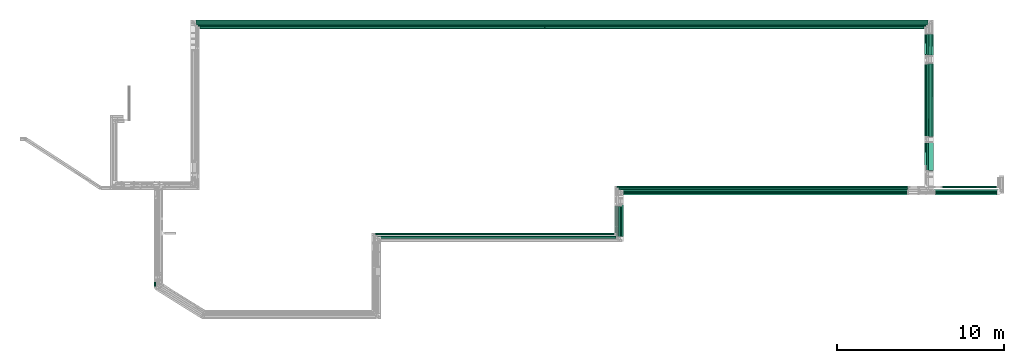
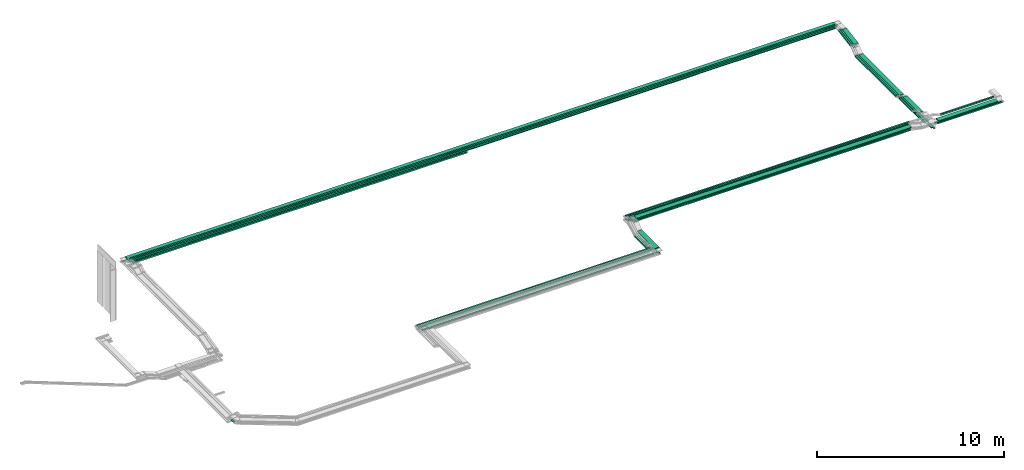
# One storey, part 2 of 14: 42 flow segments.
"""IFC2X3 building model written with IfcOpenShell, lengths in millimetres."""

from ifc_helpers import new_model, entity, si_unit, converted_unit, derived_unit, direction, frame, frame_2d, origin, origin_2d_with_axis, place, context, subcontext, project, spatial, rectangle, extrude, type_object, element, save


model = new_model("IFC2X3")

# Units and contexts
model_context = context("Model", 3, precision=0.01, world=origin(), true_north=direction((6.12303176911189e-17, 1.0)))
body_context = subcontext(model_context, "Body", "Model", "MODEL_VIEW")
ifc_project = project(units=[si_unit("LENGTHUNIT", "METRE", prefix="MILLI"), si_unit("AREAUNIT", "SQUARE_METRE"), si_unit("VOLUMEUNIT", "CUBIC_METRE"), converted_unit("PLANEANGLEUNIT", "DEGREE", entity("IfcRatioMeasure", 0.0174532925199433), si_unit("PLANEANGLEUNIT", "RADIAN"), dimensions=[0, 0, 0, 0, 0, 0, 0]), si_unit("MASSUNIT", "GRAM", prefix="KILO"), derived_unit("MASSDENSITYUNIT", [(si_unit("MASSUNIT", "GRAM", prefix="KILO"), 1), (si_unit("LENGTHUNIT", "METRE"), -3)]), derived_unit("MOMENTOFINERTIAUNIT", [(si_unit("LENGTHUNIT", "METRE"), 4)]), si_unit("TIMEUNIT", "SECOND"), si_unit("FREQUENCYUNIT", "HERTZ"), si_unit("THERMODYNAMICTEMPERATUREUNIT", "DEGREE_CELSIUS"), derived_unit("THERMALTRANSMITTANCEUNIT", [(si_unit("MASSUNIT", "GRAM", prefix="KILO"), 1), (si_unit("THERMODYNAMICTEMPERATUREUNIT", "KELVIN"), -1), (si_unit("TIMEUNIT", "SECOND"), -3)]), derived_unit("VOLUMETRICFLOWRATEUNIT", [(si_unit("LENGTHUNIT", "METRE"), 3), (si_unit("TIMEUNIT", "SECOND"), -1)]), derived_unit("MASSFLOWRATEUNIT", [(si_unit("MASSUNIT", "GRAM", prefix="KILO"), 1), (si_unit("TIMEUNIT", "SECOND"), -1)]), derived_unit("ROTATIONALFREQUENCYUNIT", [(si_unit("TIMEUNIT", "SECOND"), -1)]), si_unit("ELECTRICCURRENTUNIT", "AMPERE"), si_unit("ELECTRICVOLTAGEUNIT", "VOLT"), si_unit("POWERUNIT", "WATT"), si_unit("FORCEUNIT", "NEWTON", prefix="KILO"), si_unit("ILLUMINANCEUNIT", "LUX"), si_unit("LUMINOUSFLUXUNIT", "LUMEN"), si_unit("LUMINOUSINTENSITYUNIT", "CANDELA"), derived_unit("USERDEFINED", [(si_unit("MASSUNIT", "GRAM", prefix="KILO"), -1), (si_unit("LENGTHUNIT", "METRE"), -2), (si_unit("TIMEUNIT", "SECOND"), 3), (si_unit("LUMINOUSFLUXUNIT", "LUMEN"), 1)]), derived_unit("LINEARVELOCITYUNIT", [(si_unit("LENGTHUNIT", "METRE"), 1), (si_unit("TIMEUNIT", "SECOND"), -1)]), si_unit("PRESSUREUNIT", "PASCAL"), derived_unit("USERDEFINED", [(si_unit("LENGTHUNIT", "METRE"), -2), (si_unit("MASSUNIT", "GRAM", prefix="KILO"), 1), (si_unit("TIMEUNIT", "SECOND"), -2)]), derived_unit("LINEARFORCEUNIT", [(si_unit("MASSUNIT", "GRAM", prefix="KILO"), 1), (si_unit("LENGTHUNIT", "METRE"), 1), (si_unit("TIMEUNIT", "SECOND"), -2), (si_unit("LENGTHUNIT", "METRE"), -1)]), derived_unit("PLANARFORCEUNIT", [(si_unit("MASSUNIT", "GRAM", prefix="KILO"), 1), (si_unit("LENGTHUNIT", "METRE"), 1), (si_unit("TIMEUNIT", "SECOND"), -2), (si_unit("LENGTHUNIT", "METRE"), -2)])], contexts=[model_context])

# Site, building, storey
site_placement = place(None, origin())
site = spatial("IfcSite", under=ifc_project, at=site_placement, CompositionType="ELEMENT")
building_placement = place(site_placement, origin())
building = spatial("IfcBuilding", under=site, at=building_placement, CompositionType="ELEMENT")
storey_placement = place(building_placement, frame((0.0, 0.0, 19800.0)))
storey = spatial("IfcBuildingStorey", under=building, at=storey_placement, CompositionType="ELEMENT", Elevation=19800.0)

# Flow segments
cable_carrier_segment_type = type_object("IfcCableCarrierSegmentType", PredefinedType="CABLETRAYSEGMENT")
flow_segment_1_placement = place(storey_placement, frame((20510.22, 19700.0, 3300.0)))
element("IfcFlowSegment", 1, at=flow_segment_1_placement, inside=storey, type_object=cable_carrier_segment_type, context=body_context, shape_type="SweptSolid", body=[
    extrude(rectangle(XDim=43861.6970823392, YDim=300.000000000001, at=origin_2d_with_axis()), frame((21930.85, 150.0, 0.0), z_axis=(3.27264479763197e-08, 0.0, 1.0), x_axis=(-1.0, 0.0, 3.27264479763197e-08)), (0.0, 0.0, 1.0), 49.9999999999973),
])
flow_segment_2_placement = place(storey_placement, frame((20615.22, 19595.0, 3300.0)))
element("IfcFlowSegment", 2, at=flow_segment_2_placement, inside=storey, type_object=cable_carrier_segment_type, context=body_context, shape_type="SweptSolid", body=[
    extrude(rectangle(XDim=43650.3107133575, YDim=100.000000000003, at=origin_2d_with_axis()), frame((21825.16, 50.0, 0.0), z_axis=(0.0, 0.0, 1.0), x_axis=(-1.0, 0.0, 0.0)), (0.0, 0.0, 1.0), 100.000000000003),
])
flow_segment_3_placement = place(storey_placement, frame((20720.22, 19490.0, 3300.0)))
element("IfcFlowSegment", 3, at=flow_segment_3_placement, inside=storey, type_object=cable_carrier_segment_type, context=body_context, shape_type="SweptSolid", body=[
    extrude(rectangle(XDim=43439.8425431613, YDim=100.000000000001, at=origin_2d_with_axis()), frame((21719.92, 50.0, 0.0), z_axis=(0.0, 0.0, 1.0), x_axis=(-1.0, 0.0, 0.0)), (0.0, 0.0, 1.0), 100.000000000003),
])
flow_segment_4_placement = place(storey_placement, frame((64593.04, 9615.0, 2550.0)))
element("IfcFlowSegment", 4, at=flow_segment_4_placement, inside=storey, type_object=cable_carrier_segment_type, context=body_context, shape_type="SweptSolid", body=[
    extrude(rectangle(XDim=7760.0992906484, YDim=99.9999999999946, at=origin_2d_with_axis()), frame((50.0, 3880.05, 0.0), z_axis=(0.0, 0.0, 1.0), x_axis=(0.0, -1.0, 0.0)), (0.0, 0.0, 1.0), 49.9999999999973),
])
flow_segment_5_placement = place(storey_placement, frame((64490.53, 9720.0, 2550.0)))
element("IfcFlowSegment", 5, at=flow_segment_5_placement, inside=storey, type_object=cable_carrier_segment_type, context=body_context, shape_type="SweptSolid", body=[
    extrude(rectangle(XDim=7655.09929065903, YDim=99.9999999999946, at=origin_2d_with_axis()), frame((50.0, 3827.55, 0.0), z_axis=(0.0, 0.0, 1.0), x_axis=(0.0, -1.0, 0.0)), (0.0, 0.0, 1.0), 49.9999999999973),
])
flow_segment_6_placement = place(storey_placement, frame((64388.57, 10290.0, 2550.0)))
element("IfcFlowSegment", 6, at=flow_segment_6_placement, inside=storey, type_object=cable_carrier_segment_type, context=body_context, shape_type="SweptSolid", body=[
    extrude(rectangle(XDim=7085.0992906527, YDim=99.9999999999946, at=origin_2d_with_axis()), frame((50.0, 3542.55, 0.0), z_axis=(0.0, 0.0, 1.0), x_axis=(0.0, -1.0, 0.0)), (0.0, 0.0, 1.0), 49.9999999999973),
])
flow_segment_7_placement = place(storey_placement, frame((20720.22, 19490.0, 3100.0)))
element("IfcFlowSegment", 7, at=flow_segment_7_placement, inside=storey, type_object=cable_carrier_segment_type, context=body_context, shape_type="SweptSolid", body=[
    extrude(rectangle(XDim=20698.7834674717, YDim=100.000000000001, at=origin_2d_with_axis()), frame((10349.39, 50.0, 0.0), z_axis=(0.0, 0.0, 1.0), x_axis=(-1.0, 0.0, 0.0)), (0.0, 0.0, 1.0), 100.000000000003),
])
flow_segment_8_placement = place(storey_placement, frame((20310.22, 19900.0, 3100.0)))
element("IfcFlowSegment", 8, at=flow_segment_8_placement, inside=storey, type_object=cable_carrier_segment_type, context=body_context, shape_type="SweptSolid", body=[
    extrude(rectangle(XDim=44262.8208978618, YDim=100.000000000003, at=origin_2d_with_axis()), frame((22131.41, 50.0, 0.0), z_axis=(0.0, 0.0, 1.0), x_axis=(-1.0, 0.0, 0.0)), (0.0, 0.0, 1.0), 49.9999999999973),
])
flow_segment_9_placement = place(storey_placement, frame((20415.22, 19795.0, 3100.0)))
element("IfcFlowSegment", 9, at=flow_segment_9_placement, inside=storey, type_object=cable_carrier_segment_type, context=body_context, shape_type="SweptSolid", body=[
    extrude(rectangle(XDim=44055.3107133575, YDim=100.000000000003, at=origin_2d_with_axis()), frame((22027.66, 50.0, 0.0), z_axis=(0.0, 0.0, 1.0), x_axis=(-1.0, 0.0, 0.0)), (0.0, 0.0, 1.0), 49.9999999999973),
])
flow_segment_10_placement = place(storey_placement, frame((20520.22, 19690.0, 3100.0)))
element("IfcFlowSegment", 10, at=flow_segment_10_placement, inside=storey, type_object=cable_carrier_segment_type, context=body_context, shape_type="SweptSolid", body=[
    extrude(rectangle(XDim=43848.3558915892, YDim=100.000000000003, at=origin_2d_with_axis()), frame((21924.18, 50.0, 0.0), z_axis=(0.0, 0.0, 1.0), x_axis=(-1.0, 0.0, 0.0)), (0.0, 0.0, 1.0), 49.9999999999973),
])
flow_segment_11_placement = place(storey_placement, frame((46136.39, 9515.0, 3175.0)))
element("IfcFlowSegment", 11, at=flow_segment_11_placement, inside=storey, type_object=cable_carrier_segment_type, context=body_context, shape_type="SweptSolid", body=[
    extrude(rectangle(XDim=17012.5626625772, YDim=300.000000000001, at=origin_2d_with_axis()), frame((8506.28, 150.0, 0.0), z_axis=(0.0, 6.09869900927148e-08, 1.0), x_axis=(-1.0, 0.0, 0.0)), (0.0, 0.0, 1.0), 50.0000000000017),
])
flow_segment_12_placement = place(storey_placement, frame((45715.12, 9945.0, 3175.0)))
element("IfcFlowSegment", 12, at=flow_segment_12_placement, inside=storey, type_object=cable_carrier_segment_type, context=body_context, shape_type="SweptSolid", body=[
    extrude(rectangle(XDim=17558.63871242, YDim=99.9999999999989, at=origin_2d_with_axis()), frame((8779.32, 50.0, 0.0), z_axis=(0.0, 0.0, 1.0), x_axis=(-1.0, 0.0, 0.0)), (0.0, 0.0, 1.0), 100.000000000003),
])
flow_segment_13_placement = place(storey_placement, frame((31167.89, 7125.0, 2800.0)))
element("IfcFlowSegment", 13, at=flow_segment_13_placement, inside=storey, type_object=cable_carrier_segment_type, context=body_context, shape_type="SweptSolid", body=[
    extrude(rectangle(XDim=14407.2299237504, YDim=100.000000000001, at=origin_2d_with_axis()), frame((7203.61, 50.0, 0.0), z_axis=(0.0, 0.0, 1.0), x_axis=(-1.0, 0.0, 0.0)), (0.0, 0.0, 1.0), 100.000000000003),
])
flow_segment_14_placement = place(storey_placement, frame((31369.29, 6927.78, 2600.0)))
element("IfcFlowSegment", 14, at=flow_segment_14_placement, inside=storey, type_object=cable_carrier_segment_type, context=body_context, shape_type="SweptSolid", body=[
    extrude(rectangle(XDim=14320.0, YDim=99.9999999999989, at=origin_2d_with_axis()), frame((7160.0, 50.0, 0.0), z_axis=(0.0, 0.0, 1.0), x_axis=(-1.0, 0.0, 0.0)), (0.0, 0.0, 1.0), 49.9999999999973),
])
flow_segment_15_placement = place(storey_placement, frame((31245.11, 7125.0, 2600.0)))
element("IfcFlowSegment", 15, at=flow_segment_15_placement, inside=storey, type_object=cable_carrier_segment_type, context=body_context, shape_type="SweptSolid", body=[
    extrude(rectangle(XDim=14330.0132597468, YDim=99.9999999999989, at=origin_2d_with_axis()), frame((7165.01, 50.0, 0.0), z_axis=(0.0, 0.0, 1.0), x_axis=(-1.0, 0.0, 0.0)), (0.0, 0.0, 1.0), 100.000000000003),
])
flow_segment_16_placement = place(storey_placement, frame((64391.91, 17890.77, 3082.61)))
element("IfcFlowSegment", 16, at=flow_segment_16_placement, inside=storey, type_object=cable_carrier_segment_type, context=body_context, shape_type="SweptSolid", body=[
    extrude(rectangle(XDim=49.9999999999963, YDim=1283.81748851725, at=frame_2d((0.0, 0.0), x_axis=(0.0, 1.0))), frame((0.0, 636.96, 132.7), z_axis=(1.0, 0.0, 0.0), x_axis=(0.0, -0.985728987268031, -0.168340023938282)), (0.0, 0.0, 1.0), 300.000000000001),
])
for number, where in (
    (17, (64285.53, 17888.86, 3083.36)),
    (18, (64180.06, 17888.86, 3083.36)),
):
    element("IfcFlowSegment", number, at=place(storey_placement, frame(where)), inside=storey, type_object=cable_carrier_segment_type, context=body_context, shape_type="SweptSolid", body=[
        extrude(rectangle(XDim=100.000000000001, YDim=99.9999999999946, at=origin_2d_with_axis()), frame((50.0, 8.42, 49.29), z_axis=(0.0, 0.985728987268031, 0.168340023938282), x_axis=(0.0, -0.168340023938282, 0.985728987268031)), (0.0, 0.0, 1.0), 1277.24793927283),
    ])
for number, where in (
    (19, (64593.04, 17882.63, 2877.81)),
    (20, (64490.53, 17882.63, 2877.81)),
    (21, (64388.57, 17882.63, 2877.81)),
):
    element("IfcFlowSegment", number, at=place(storey_placement, frame(where)), inside=storey, type_object=cable_carrier_segment_type, context=body_context, shape_type="SweptSolid", body=[
        extrude(rectangle(XDim=49.9999999999963, YDim=1312.36750384491, at=frame_2d((0.0, 0.0), x_axis=(0.0, 1.0))), frame((0.0, 651.03, 135.11), z_axis=(1.0, 0.0, 0.0), x_axis=(0.0, -0.985728987268033, -0.168340023938271)), (0.0, 0.0, 1.0), 99.9999999999945),
    ])
flow_segment_17_placement = place(storey_placement, frame((64285.55, 10981.49, 2800.0)))
element("IfcFlowSegment", 22, at=flow_segment_17_placement, inside=storey, type_object=cable_carrier_segment_type, context=body_context, shape_type="SweptSolid", body=[
    extrude(rectangle(XDim=1669.27622341284, YDim=99.999999999908, at=origin_2d_with_axis()), frame((50.0, 834.65, 0.09), z_axis=(0.0, -0.000110170861433383, 0.999999993931191), x_axis=(0.0, 0.999999993931191, 0.000110170861433383)), (0.0, 0.0, 1.0), 99.9999999999068),
])
flow_segment_18_placement = place(storey_placement, frame((64180.06, 11289.13, 2800.0)))
element("IfcFlowSegment", 23, at=flow_segment_18_placement, inside=storey, type_object=cable_carrier_segment_type, context=body_context, shape_type="SweptSolid", body=[
    extrude(rectangle(XDim=1361.64006742099, YDim=99.9999999999946, at=origin_2d_with_axis()), frame((50.0, 680.83, 0.09), z_axis=(0.0, -0.000133755597263879, 0.99999999105472), x_axis=(0.0, 0.99999999105472, 0.000133755597263879)), (0.0, 0.0, 1.0), 99.9999999999964),
])
flow_segment_19_placement = place(storey_placement, frame((64393.04, 10968.1, 2800.0)))
element("IfcFlowSegment", 24, at=flow_segment_19_placement, inside=storey, type_object=cable_carrier_segment_type, context=body_context, shape_type="SweptSolid", body=[
    extrude(rectangle(XDim=1687.04298934208, YDim=300.000000000001, at=origin_2d_with_axis()), frame((150.0, 843.52, 0.0), z_axis=(0.0, 0.0, 1.0), x_axis=(0.0, 1.0, 0.0)), (0.0, 0.0, 1.0), 49.9999999999973),
])
flow_segment_20_placement = place(storey_placement, frame((45595.12, 7245.0, 2600.0)))
element("IfcFlowSegment", 25, at=flow_segment_20_placement, inside=storey, type_object=cable_carrier_segment_type, context=body_context, shape_type="SweptSolid", body=[
    extrude(rectangle(XDim=1580.56637967652, YDim=99.9999999999946, at=origin_2d_with_axis()), frame((50.0, 790.28, 0.0), z_axis=(0.0, 0.0, 1.0), x_axis=(0.0, 1.0, 0.0)), (0.0, 0.0, 1.0), 100.000000000003),
])
flow_segment_21_placement = place(storey_placement, frame((45709.29, 7047.78, 2600.0)))
element("IfcFlowSegment", 26, at=flow_segment_21_placement, inside=storey, type_object=cable_carrier_segment_type, context=body_context, shape_type="SweptSolid", body=[
    extrude(rectangle(XDim=1790.25375258002, YDim=99.9999999999946, at=origin_2d_with_axis()), frame((50.0, 895.13, 0.0), z_axis=(0.0, 0.0, 1.0), x_axis=(0.0, 1.0, 0.0)), (0.0, 0.0, 1.0), 49.999999999993),
])
flow_segment_22_placement = place(storey_placement, frame((45821.5, 6942.78, 2600.0)))
element("IfcFlowSegment", 27, at=flow_segment_22_placement, inside=storey, type_object=cable_carrier_segment_type, context=body_context, shape_type="SweptSolid", body=[
    extrude(rectangle(XDim=1895.25375258002, YDim=99.9999999999946, at=origin_2d_with_axis()), frame((50.0, 947.63, 0.0), z_axis=(0.0, 0.0, 1.0), x_axis=(0.0, 1.0, 0.0)), (0.0, 0.0, 1.0), 50.0000000000016),
])
flow_segment_23_placement = place(storey_placement, frame((45934.76, 6837.78, 2600.0)))
element("IfcFlowSegment", 28, at=flow_segment_23_placement, inside=storey, type_object=cable_carrier_segment_type, context=body_context, shape_type="SweptSolid", body=[
    extrude(rectangle(XDim=2000.25375258002, YDim=99.9999999999946, at=origin_2d_with_axis()), frame((50.0, 1000.13, 0.0), z_axis=(0.0, 0.0, 1.0), x_axis=(0.0, 1.0, 0.0)), (0.0, 0.0, 1.0), 49.999999999993),
])
flow_segment_24_placement = place(storey_placement, frame((45816.39, 7037.78, 2800.0)))
element("IfcFlowSegment", 29, at=flow_segment_24_placement, inside=storey, type_object=cable_carrier_segment_type, context=body_context, shape_type="SweptSolid", body=[
    extrude(rectangle(XDim=1884.43926960423, YDim=300.000000000001, at=origin_2d_with_axis()), frame((150.0, 942.22, 0.0), z_axis=(0.0, 0.0, 1.0), x_axis=(0.0, 1.0, 0.0)), (0.0, 0.0, 1.0), 49.9999999999973),
])
flow_segment_25_placement = place(storey_placement, frame((18007.14, 4020.35, 3000.0)))
element("IfcFlowSegment", 30, at=flow_segment_25_placement, inside=storey, type_object=cable_carrier_segment_type, context=body_context, shape_type="SweptSolid", body=[
    extrude(rectangle(XDim=303.89022785907, YDim=99.9999999999989, at=origin_2d_with_axis()), frame((50.0, 151.95, 0.0), z_axis=(0.0, 0.0, 1.0), x_axis=(0.0, 1.0, 0.0)), (0.0, 0.0, 1.0), 49.9999999999973),
])
flow_segment_26_placement = place(storey_placement, frame((64823.04, 9615.0, 2800.0)))
element("IfcFlowSegment", 31, at=flow_segment_26_placement, inside=storey, type_object=cable_carrier_segment_type, context=body_context, shape_type="SweptSolid", body=[
    extrude(rectangle(XDim=3987.54391835811, YDim=100.000000000001, at=origin_2d_with_axis()), frame((1993.77, 50.0, 0.0)), (0.0, 0.0, 1.0), 49.9999999999973),
])
flow_segment_27_placement = place(storey_placement, frame((64720.53, 9720.0, 2800.0)))
element("IfcFlowSegment", 32, at=flow_segment_27_placement, inside=storey, type_object=cable_carrier_segment_type, context=body_context, shape_type="SweptSolid", body=[
    extrude(rectangle(XDim=3976.91068107751, YDim=99.9999999999989, at=origin_2d_with_axis()), frame((1988.46, 50.0, 0.0)), (0.0, 0.0, 1.0), 49.9999999999973),
])
flow_segment_28_placement = place(storey_placement, frame((65228.96, 9945.0, 3000.0)))
element("IfcFlowSegment", 33, at=flow_segment_28_placement, inside=storey, type_object=cable_carrier_segment_type, context=body_context, shape_type="SweptSolid", body=[
    extrude(rectangle(XDim=3274.30346905501, YDim=99.9999999999989, at=origin_2d_with_axis()), frame((1637.15, 50.0, 0.0)), (0.0, 0.0, 1.0), 100.000000000003),
])
flow_segment_29_placement = place(storey_placement, frame((45829.29, 9836.0, 3175.0)))
element("IfcFlowSegment", 34, at=flow_segment_29_placement, inside=storey, type_object=cable_carrier_segment_type, context=body_context, shape_type="SweptSolid", body=[
    extrude(rectangle(XDim=17320.17589421, YDim=100.000000000001, at=origin_2d_with_axis()), frame((8660.09, 50.0, 0.0), z_axis=(-1.88655445451045e-09, 2.03663483944181e-07, 1.0), x_axis=(-1.0, 0.0, -1.8865544545043e-09)), (0.0, 0.0, 1.0), 99.9999999999967),
])
flow_segment_30_placement = place(storey_placement, frame((45715.12, 9945.0, 2950.0)))
element("IfcFlowSegment", 35, at=flow_segment_30_placement, inside=storey, type_object=cable_carrier_segment_type, context=body_context, shape_type="SweptSolid", body=[
    extrude(rectangle(XDim=17434.9052265142, YDim=99.9999999999989, at=origin_2d_with_axis()), frame((8717.45, 50.0, 0.0), z_axis=(0.0, 0.0, 1.0), x_axis=(-1.0, 0.0, 0.0)), (0.0, 0.0, 1.0), 100.000000000003),
])
flow_segment_31_placement = place(storey_placement, frame((45829.29, 9825.0, 2950.0)))
element("IfcFlowSegment", 36, at=flow_segment_31_placement, inside=storey, type_object=cable_carrier_segment_type, context=body_context, shape_type="SweptSolid", body=[
    extrude(rectangle(XDim=17326.3300603298, YDim=99.9999999999989, at=origin_2d_with_axis()), frame((8663.17, 50.0, 0.0), z_axis=(0.0, 0.0, 1.0), x_axis=(-1.0, 0.0, 0.0)), (0.0, 0.0, 1.0), 49.9999999999973),
])
flow_segment_32_placement = place(storey_placement, frame((45941.5, 9720.0, 2950.0)))
element("IfcFlowSegment", 37, at=flow_segment_32_placement, inside=storey, type_object=cable_carrier_segment_type, context=body_context, shape_type="SweptSolid", body=[
    extrude(rectangle(XDim=17216.2477546201, YDim=99.9999999999989, at=origin_2d_with_axis()), frame((8608.12, 50.0, 0.0), z_axis=(0.0, 0.0, 1.0), x_axis=(-1.0, 0.0, 0.0)), (0.0, 0.0, 1.0), 49.9999999999973),
])
flow_segment_33_placement = place(storey_placement, frame((46054.76, 9615.0, 2950.0)))
element("IfcFlowSegment", 38, at=flow_segment_33_placement, inside=storey, type_object=cable_carrier_segment_type, context=body_context, shape_type="SweptSolid", body=[
    extrude(rectangle(XDim=17117.3462182917, YDim=100.000000000001, at=origin_2d_with_axis()), frame((8558.67, 50.0, 0.0), z_axis=(0.0, 0.0, 1.0), x_axis=(-1.0, 0.0, 0.0)), (0.0, 0.0, 1.0), 49.9999999999973),
])
flow_segment_34_placement = place(storey_placement, frame((64391.92, 13008.63, 2700.0)))
element("IfcFlowSegment", 39, at=flow_segment_34_placement, inside=storey, type_object=cable_carrier_segment_type, context=body_context, shape_type="SweptSolid", body=[
    extrude(rectangle(XDim=4374.71884293394, YDim=300.000000000004, at=origin_2d_with_axis()), frame((150.56, 2187.4, 0.0), z_axis=(0.0, 0.0, 1.0), x_axis=(0.000254693966544882, -0.999999967565491, 0.0)), (0.0, 0.0, 1.0), 49.999999999993),
])
flow_segment_35_placement = place(storey_placement, frame((64285.55, 13019.25, 2700.19)))
element("IfcFlowSegment", 40, at=flow_segment_35_placement, inside=storey, type_object=cable_carrier_segment_type, context=body_context, shape_type="SweptSolid", body=[
    extrude(rectangle(XDim=4338.3016544712, YDim=99.999999841948, at=origin_2d_with_axis()), frame((50.0, 2169.15, 0.0), z_axis=(0.0, -2.64388587007212e-07, 1.0), x_axis=(0.0, 1.0, 2.64388587007212e-07)), (0.0, 0.0, 1.0), 99.9999998419428),
])
flow_segment_36_placement = place(storey_placement, frame((64180.06, 13019.25, 2700.19)))
element("IfcFlowSegment", 41, at=flow_segment_36_placement, inside=storey, type_object=cable_carrier_segment_type, context=body_context, shape_type="SweptSolid", body=[
    extrude(rectangle(XDim=4338.30020865616, YDim=99.9999999999951, at=origin_2d_with_axis()), frame((50.0, 2169.15, 0.0), z_axis=(0.0, 0.0, 1.0), x_axis=(-9.64493498738689e-08, 1.0, 0.0)), (0.0, 0.0, 1.0), 100.000000000003),
])
flow_segment_37_placement = place(storey_placement, frame((64823.04, 9515.0, 3000.0)))
element("IfcFlowSegment", 42, at=flow_segment_37_placement, inside=storey, type_object=cable_carrier_segment_type, context=body_context, shape_type="SweptSolid", body=[
    extrude(rectangle(XDim=3679.75388627882, YDim=300.000000000001, at=origin_2d_with_axis()), frame((1839.88, 150.0, 0.0)), (0.0, 0.0, 1.0), 49.9999999999973),
])

save(model, "model.ifc")
